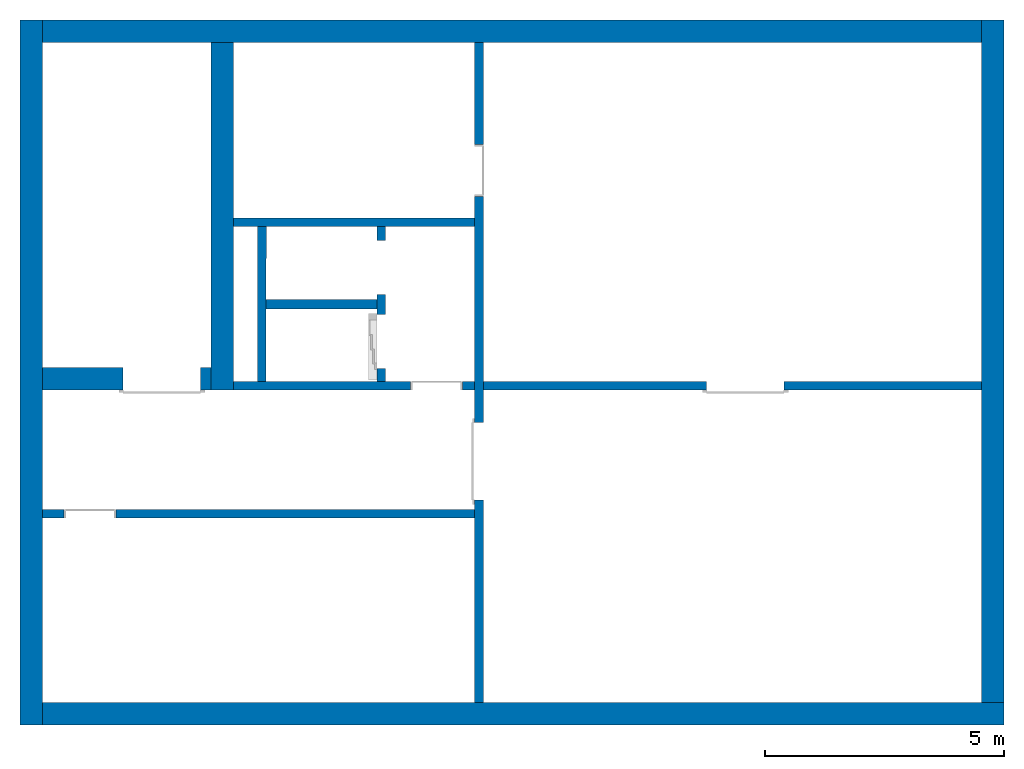
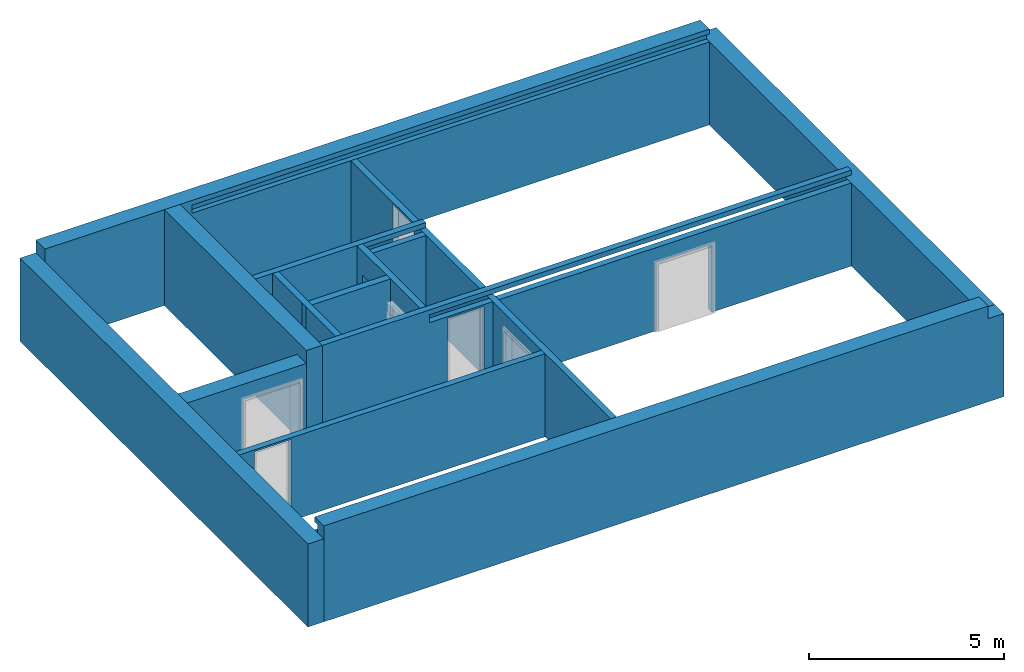
# One storey, part 1 of 3: 13 walls, 8 openings.
"""IFC4 building model written with IfcOpenShell, lengths in metres."""

import ifcopenshell
import ifcopenshell.guid

model = None  # the IFC model being written
_history = None  # IfcOwnerHistory: only IFC2X3 demands one
_inside = {}  # id of a spatial element -> (the spatial element, [elements in it])
_under = {}  # id of a project, library or spatial element -> (it, [spatial elements below it])
_declared = {}  # id of a project -> (the project, [libraries it declares])
_typed = {}  # id of a type object -> (the type object, [elements of that type])
_made_of = {}  # id of a material, layer set ... -> (it, [elements and type objects made of it])


def new_model(schema):
    """Start an empty IFC model of exactly this schema.

    Asked for "IFC4X3", IfcOpenShell would pick the latest addendum, in which some entities
    have other attributes; the version numbers below select the first issue.
    IFC2X3 requires an IfcOwnerHistory on every rooted entity: one is made here for all.
    """
    global model, _history
    if schema == "IFC4X3":
        model = ifcopenshell.file(schema_version=(4, 3, 0, 0))
    else:
        model = ifcopenshell.file(schema=schema)
    _inside.clear()
    _under.clear()
    _declared.clear()
    _typed.clear()
    _made_of.clear()
    _history = None
    if model.schema == "IFC2X3":
        org = make("IfcOrganization", Name="unknown")
        user = make(
            "IfcPersonAndOrganization",
            ThePerson=make("IfcPerson", FamilyName="unknown"),
            TheOrganization=org,
        )
        app = make(
            "IfcApplication",
            ApplicationDeveloper=org,
            Version="unknown",
            ApplicationFullName="unknown",
            ApplicationIdentifier="unknown",
        )
        _history = make(
            "IfcOwnerHistory",
            OwningUser=user,
            OwningApplication=app,
            ChangeAction="ADDED",
            CreationDate=0,
        )
    return model


def make(cls, **values):
    """One entity of the class cls with the attributes given. An attribute that is None is left unset."""
    return model.create_entity(
        cls, **{name: value for name, value in values.items() if value is not None}
    )


def entity(cls, *values):
    """Any entity or typed value of the class cls, its attributes in the order of the schema. None: left unset."""
    e = model.create_entity(cls)
    for i, value in enumerate(values):
        if value is not None:
            e[i] = value
    return e


def rooted(cls, **values):
    """An entity with a GlobalId (a new one), such as an element, a storey or a relation."""
    return make(cls, GlobalId=ifcopenshell.guid.new(), OwnerHistory=_history, **values)


def si_unit(unit_type, name, prefix=None):
    """IfcSIUnit, for example si_unit("LENGTHUNIT", "METRE", prefix="MILLI")."""
    return make("IfcSIUnit", UnitType=unit_type, Prefix=prefix, Name=name)


def converted_unit(unit_type, name, factor, base, dimensions=None, offset=None):
    """IfcConversionBasedUnit, such as the inch: factor (a typed value) times the base unit."""
    return make(
        "IfcConversionBasedUnit"
        if offset is None
        else "IfcConversionBasedUnitWithOffset",
        ConversionOffset=offset,
        Dimensions=None
        if dimensions is None
        else entity("IfcDimensionalExponents", *dimensions),
        UnitType=unit_type,
        Name=name,
        ConversionFactor=make(
            "IfcMeasureWithUnit", ValueComponent=factor, UnitComponent=base
        ),
    )


def derived_unit(unit_type, elements):
    """IfcDerivedUnit: a product of units, each with its exponent."""
    return make(
        "IfcDerivedUnit",
        Elements=[
            make("IfcDerivedUnitElement", Unit=unit, Exponent=power)
            for unit, power in elements
        ],
        UnitType=unit_type,
    )


def assignment(units):
    """IfcUnitAssignment: the units of a project."""
    return None if units is None else make("IfcUnitAssignment", Units=units)


def point(xyz):
    """IfcCartesianPoint."""
    return None if xyz is None else make("IfcCartesianPoint", Coordinates=xyz)


def direction(xyz):
    """IfcDirection."""
    return None if xyz is None else make("IfcDirection", DirectionRatios=xyz)


def frame(location, z_axis=None, x_axis=None):
    """IfcAxis2Placement3D, a coordinate frame: its origin and axes. An axis left out is left unset."""
    return make(
        "IfcAxis2Placement3D",
        Location=point(location),
        Axis=direction(z_axis),
        RefDirection=direction(x_axis),
    )


def origin_with_axes():
    """The frame at (0, 0, 0) with the z axis (0, 0, 1) and the x axis (1, 0, 0) written out."""
    return frame((0.0, 0.0, 0.0), z_axis=(0.0, 0.0, 1.0), x_axis=(1.0, 0.0, 0.0))


def place(relative_to, where):
    """IfcLocalPlacement: puts the frame where relative to a parent placement (None: the world)."""
    return make(
        "IfcLocalPlacement", PlacementRelTo=relative_to, RelativePlacement=where
    )


def context(
    kind, dimensions, precision=None, world=None, true_north=None, identifier=None
):
    """IfcGeometricRepresentationContext, for example the 3D "Model" context."""
    return make(
        "IfcGeometricRepresentationContext",
        ContextIdentifier=identifier,
        ContextType=kind,
        CoordinateSpaceDimension=dimensions,
        Precision=precision,
        WorldCoordinateSystem=world,
        TrueNorth=true_north,
    )


def subcontext(parent, identifier, kind, view, scale=None):
    """IfcGeometricRepresentationSubContext, for example "Body" below "Model"."""
    return make(
        "IfcGeometricRepresentationSubContext",
        ContextIdentifier=identifier,
        ContextType=kind,
        ParentContext=parent,
        TargetScale=scale,
        TargetView=view,
    )


def project(units=None, contexts=None):
    """IfcProject with its units and contexts."""
    return rooted(
        "IfcProject",
        Name="project",
        RepresentationContexts=contexts,
        UnitsInContext=assignment(units),
    )


def spatial(cls, under=None, at=None, **own):
    """A site, building, storey or space (cls), placed at a placement, below another one or the project."""
    s = rooted(cls, ObjectPlacement=at, **own)
    if under is not None:
        _under.setdefault(under.id(), (under, []))[1].append(s)
    return s


def point_list(points):
    """IfcCartesianPointList2D or 3D."""
    cls = (
        "IfcCartesianPointList2D" if len(points[0]) == 2 else "IfcCartesianPointList3D"
    )
    return make(cls, CoordList=points)


def polygons(points, faces, closed=None, point_numbers=None):
    """IfcPolygonalFaceSet: a face is its outer loop, then its inner loops; points numbered from 1."""
    made = []
    for loops in faces:
        if len(loops) == 1:
            made.append(make("IfcIndexedPolygonalFace", CoordIndex=loops[0]))
        else:
            made.append(
                make(
                    "IfcIndexedPolygonalFaceWithVoids",
                    CoordIndex=loops[0],
                    InnerCoordIndices=loops[1:],
                )
            )
    return make(
        "IfcPolygonalFaceSet",
        Coordinates=point_list(points),
        Closed=closed,
        Faces=made,
        PnIndex=point_numbers,
    )


def shape(context_of_items, identifier, shape_type, items):
    """IfcShapeRepresentation: the items that make up one representation, for example the "Body"."""
    return make(
        "IfcShapeRepresentation",
        ContextOfItems=context_of_items,
        RepresentationIdentifier=identifier,
        RepresentationType=shape_type,
        Items=items,
    )


def material(Name=None, Category=None):
    """IfcMaterial."""
    return make("IfcMaterial", Name=Name, Category=Category)


def made_of(thing, what):
    """Note that an element or type object is made of a material, layer set ...; save() writes the relation."""
    if what is not None:
        _made_of.setdefault(what.id(), (what, []))[1].append(thing)
    return thing


def type_object(cls, material=None, **own):
    """A type object (cls), such as IfcWallType, which elements share."""
    return made_of(rooted(cls, **own), material)


def element(
    cls,
    number,
    at=None,
    inside=None,
    cuts=None,
    type_object=None,
    material=None,
    context=None,
    identifier="Body",
    shape_type=None,
    held_by="IfcProductDefinitionShape",
    body=None,
    shapes=None,
    **own,
):
    """One element of the class cls, such as IfcWall. Its Tag is "e" and its number.

    at: its placement. inside: the storey or other place that contains it. cuts: it is an
    opening in that element (IfcRelVoidsElement). A single representation is given by context,
    identifier, shape_type and body (its items); several are given by shapes. held_by: the class
    of the entity that holds the representations. save() writes the other relations.
    """
    e = rooted(cls, Tag="e%d" % number, ObjectPlacement=at, **own)
    if body is not None:
        shapes = [shape(context, identifier, shape_type, body)]
    if shapes is not None:
        e.Representation = make(held_by, Representations=shapes)
    if inside is not None:
        _inside.setdefault(inside.id(), (inside, []))[1].append(e)
    if cuts is not None:
        rooted(
            "IfcRelVoidsElement", RelatingBuildingElement=cuts, RelatedOpeningElement=e
        )
    if type_object is not None:
        _typed.setdefault(type_object.id(), (type_object, []))[1].append(e)
    return made_of(e, material)


def aggregate(whole, parts):
    """IfcRelAggregates: a whole, such as a stair, and the parts it consists of."""
    return rooted("IfcRelAggregates", RelatingObject=whole, RelatedObjects=parts)


def save(model, path):
    """Write the relations noted so far, then the file.

    IfcRelAggregates (storeys below a building ...), IfcRelContainedInSpatialStructure (elements
    in a storey), IfcRelDefinesByType, IfcRelAssociatesMaterial and IfcRelDeclares: one each for
    every whole, place, type object, material and project.
    """
    for whole, parts in _under.values():
        aggregate(whole, parts)
    for where, things in _inside.values():
        rooted(
            "IfcRelContainedInSpatialStructure",
            RelatedElements=things,
            RelatingStructure=where,
        )
    for kind, things in _typed.values():
        rooted("IfcRelDefinesByType", RelatedObjects=things, RelatingType=kind)
    for what, things in _made_of.values():
        rooted("IfcRelAssociatesMaterial", RelatedObjects=things, RelatingMaterial=what)
    for by, libraries in _declared.values():
        rooted("IfcRelDeclares", RelatingContext=by, RelatedDefinitions=libraries)
    model.write(path)


model = new_model("IFC4")

# Units and contexts
model_context = context("Model", 3, precision=1e-05, world=origin_with_axes(), true_north=direction((0.0, 1.0)))
body_context = subcontext(model_context, "Body", "Model", "MODEL_VIEW")
ifc_project = project(units=[si_unit("LENGTHUNIT", "METRE"), si_unit("AREAUNIT", "SQUARE_METRE"), si_unit("VOLUMEUNIT", "CUBIC_METRE"), converted_unit("PLANEANGLEUNIT", "DEGREE", entity("IfcPlaneAngleMeasure", 0.0174532925199433), si_unit("PLANEANGLEUNIT", "RADIAN"), dimensions=[0, 0, 0, 0, 0, 0, 0]), converted_unit("TIMEUNIT", "Year", entity("IfcTimeMeasure", 31557600.0), si_unit("TIMEUNIT", "SECOND"), dimensions=[0, 0, 1, 0, 0, 0, 0]), si_unit("MASSUNIT", "GRAM", prefix="KILO"), si_unit("THERMODYNAMICTEMPERATUREUNIT", "DEGREE_CELSIUS"), si_unit("LUMINOUSINTENSITYUNIT", "LUMEN"), si_unit("ENERGYUNIT", "JOULE", prefix="MEGA"), derived_unit("THERMALCONDUCTANCEUNIT", [(si_unit("POWERUNIT", "WATT"), 1), (si_unit("LENGTHUNIT", "METRE"), -1), (si_unit("THERMODYNAMICTEMPERATUREUNIT", "KELVIN"), -1)]), derived_unit("SPECIFICHEATCAPACITYUNIT", [(si_unit("ENERGYUNIT", "JOULE"), 1), (si_unit("MASSUNIT", "GRAM", prefix="KILO"), -1), (si_unit("THERMODYNAMICTEMPERATUREUNIT", "KELVIN"), -1)]), derived_unit("MASSDENSITYUNIT", [(si_unit("MASSUNIT", "GRAM", prefix="KILO"), 1), (si_unit("VOLUMEUNIT", "CUBIC_METRE"), -1)])], contexts=[model_context])

# Site, building, storey
site_placement = place(None, origin_with_axes())
site = spatial("IfcSite", under=ifc_project, at=site_placement, CompositionType="ELEMENT")
building_placement = place(None, origin_with_axes())
building = spatial("IfcBuilding", under=site, at=building_placement, CompositionType="ELEMENT")
storey_placement = place(None, frame((0.0, 0.0, -3.0), z_axis=(0.0, 0.0, 1.0), x_axis=(1.0, 0.0, 0.0)))
storey = spatial("IfcBuildingStorey", under=building, at=storey_placement, Name="UG", CompositionType="ELEMENT", Elevation=-3.0)

# Walls
ifc_material = material(Name="Stahlbeton")
wall_type_1 = type_object("IfcWallType", Name="Stahlbeton 180", PredefinedType="NOTDEFINED")
wall_1_placement = place(None, frame((29.1377045594425, 7.05499994546755, -3.0), z_axis=(0.0, 0.0, 1.0), x_axis=(0.00164133421967425, 0.999998653010083, 0.0)))
element("IfcWall", 1, at=wall_1_placement, inside=storey, type_object=wall_type_1, material=ifc_material, Name="Wand-001", PredefinedType="NOTDEFINED", context=body_context, shape_type="Tessellation", body=[
    polygons([(0.179704801901014, 0.18, 0.0), (3.41970916615423, 0.180000000000007, 0.0), (3.42000460671172, 0.0, 0.0), (0.180000242458512, 0.0, 0.0), (0.179704801901014, 0.18, 3.0), (3.41970916615423, 0.180000000000007, 3.0), (3.42000460671172, 0.0, 3.0), (0.180000242458512, 0.0, 3.0)], [[[1, 2, 3, 4]], [[5, 6, 2, 1]], [[7, 3, 2, 6]], [[4, 3, 7, 8]], [[8, 5, 1, 4]], [[8, 7, 6, 5]]], closed=True),
])
wall_2_placement = place(None, frame((33.505, 10.6549999454676, -3.0), z_axis=(0.0, 0.0, 1.0), x_axis=(-1.0, 0.0, 0.0)))
element("IfcWall", 2, at=wall_2_placement, inside=storey, type_object=wall_type_1, material=ifc_material, Name="Wand-003", PredefinedType="NOTDEFINED", context=body_context, shape_type="Tessellation", body=[
    polygons([(0.0, 0.18, 3.0), (0.0, 0.180000000000001, 2.85), (0.0, 0.0, 2.85), (0.0, 0.0, 3.0), (1.8669999709129, 0.18, 2.6), (1.8669999709129, 0.18, 2.85), (5.04699999999999, 0.18, 3.0), (5.04699999999999, 0.18, 0.0), (0.0, 0.18, 0.0), (0.0, 0.180000000000003, 2.6), (1.8669999709129, -8.86263311627999e-08, 2.85), (1.8669999709129, -8.86263311627999e-08, 2.6), (0.0, 0.0, 2.6), (0.0, 0.0, 0.0), (5.04699999999999, 0.0, 0.0), (5.04699999999999, 0.0, 3.0)], [[[1, 2, 3, 4]], [[5, 6, 2, 1, 7, 8, 9, 10]], [[6, 11, 3, 2]], [[11, 12, 13, 14, 15, 16, 4, 3]], [[4, 16, 7, 1]], [[5, 12, 11, 6]], [[8, 7, 16, 15]], [[8, 15, 14, 9]], [[14, 13, 10, 9]], [[5, 10, 13, 12]]], closed=True),
])

# Wall, openings
wall_3_placement = place(None, frame((27.988, 7.05499994546755, -3.0), z_axis=(0.0, 0.0, 1.0), x_axis=(1.0, 0.0, 0.0)))
wall_3 = element("IfcWall", 3, at=wall_3_placement, inside=storey, type_object=wall_type_1, material=ifc_material, Name="Wand-001", PredefinedType="NOTDEFINED", context=body_context, shape_type="Tessellation", body=[
    polygons([(10.370657642847, 0.18, 2.11), (10.370657642847, 0.18, 0.0), (5.69699999999999, 0.18, 0.0), (5.69699999999999, 0.180000000000002, 2.6), (8.20499999999999, 0.180000000000002, 2.6), (16.126, 0.180000000000001, 2.6), (16.126, 0.180000000000001, 0.0), (11.990657642847, 0.180000000000001, 0.0), (11.990657642847, 0.180000000000001, 2.11), (10.370657642847, 0.0, 2.11), (10.370657642847, 0.0, 0.0), (5.69699999999999, 0.0, 0.0), (5.69699999999999, 0.0, 2.6), (16.126, 0.0, 2.6), (16.126, 0.0, 0.0), (11.990657642847, 0.0, 0.0), (11.990657642847, 0.0, 2.11)], [[[1, 2, 3, 4, 5, 6, 7, 8, 9]], [[2, 1, 10, 11]], [[2, 11, 12, 3]], [[13, 4, 3, 12]], [[4, 13, 14, 6, 5]], [[6, 14, 15, 7]], [[16, 8, 7, 15]], [[9, 8, 16, 17]], [[1, 9, 17, 10]], [[17, 16, 15, 14, 13, 12, 11, 10]]], closed=True),
    polygons([(4.17199999999999, 0.18, 2.545), (4.17199999999999, 0.18, 0.0), (0.469999999999999, 0.18, 0.0), (0.469999999999999, 0.180000000000001, 3.0), (16.126, 0.180000000000001, 3.0), (16.126, 0.180000000000001, 2.85), (8.20499999999999, 0.180000000000002, 2.85), (5.69699999999999, 0.180000000000002, 2.85), (3.65000002908709, 0.18, 2.85), (3.65000002908709, 0.18, 2.6), (5.51699999999999, 0.18, 2.6), (5.51699999999999, 0.18, 0.0), (5.262, 0.18, 0.0), (5.262, 0.18, 2.545), (4.17199999999999, 1.29097926127031e-07, 2.545), (4.17199999999999, 0.0, 0.0), (0.469999999999999, 0.0, 0.0), (0.469999999999999, 0.0, 2.6), (0.469999999999999, 0.0, 3.0), (16.126, 0.0, 3.0), (16.126, 0.0, 2.85), (3.65000002908709, 1.29097926127031e-07, 2.85), (3.65000002908709, 1.29097926127031e-07, 2.6), (5.51699999999999, 0.0, 2.6), (5.51699999999999, 0.0, 0.0), (5.262, 0.0, 0.0), (5.262, 1.29097926127031e-07, 2.545)], [[[1, 2, 3, 4, 5, 6, 7, 8, 9, 10, 11, 12, 13, 14]], [[2, 1, 15, 16]], [[2, 16, 17, 3]], [[3, 17, 18, 19, 4]], [[5, 4, 19, 20]], [[21, 6, 5, 20]], [[6, 21, 22, 9, 8, 7]], [[10, 9, 22, 23]], [[24, 11, 10, 23]], [[11, 24, 25, 12]], [[26, 13, 12, 25]], [[14, 13, 26, 27]], [[1, 14, 27, 15]], [[27, 26, 25, 24, 23, 22, 21, 20, 19, 18, 17, 16, 15]]], closed=True),
])
opening_1_placement = place(wall_3_placement, frame((4.717, 0.0, 0.0), z_axis=(0.0, 0.0, 1.0), x_axis=(1.0, 0.0, 0.0)))
element("IfcOpeningElement", 4, at=opening_1_placement, cuts=wall_3, context=body_context, identifier="Reference", shape_type="Tessellation", body=[
    polygons([(-0.545000000000002, -0.00100000000000033, 2.545), (-0.545000000000002, -0.00100000000000033, 0.0), (0.545000000000002, -0.00100000000000033, 0.0), (0.545000000000002, -0.00100000000000033, 2.545), (-0.545000000000002, 0.181, 2.545), (-0.545000000000002, 0.181, 0.0), (0.545000000000002, 0.181, 0.0), (0.545000000000002, 0.181, 2.545)], [[[1, 2, 3, 4]], [[5, 6, 2, 1]], [[6, 7, 3, 2]], [[7, 8, 4, 3]], [[8, 5, 1, 4]], [[7, 6, 5, 8]]], closed=True),
])
opening_2_placement = place(wall_3_placement, frame((11.180657642847, 0.0, 0.0), z_axis=(0.0, 0.0, 1.0), x_axis=(1.0, 0.0, 0.0)))
element("IfcOpeningElement", 5, at=opening_2_placement, cuts=wall_3, context=body_context, identifier="Reference", shape_type="Tessellation", body=[
    polygons([(0.810000000000002, 0.181000000000002, 2.11), (0.810000000000002, 0.181000000000002, 0.0), (-0.810000000000002, 0.181000000000002, 0.0), (-0.810000000000002, 0.181000000000003, 2.11), (0.810000000000002, -0.00100000000000478, 2.11), (0.810000000000002, -0.00100000000000478, 0.0), (-0.810000000000002, -0.00100000000000478, 0.0), (-0.810000000000002, -0.00100000000000389, 2.11)], [[[1, 2, 3, 4]], [[5, 6, 2, 1]], [[6, 7, 3, 2]], [[7, 8, 4, 3]], [[8, 5, 1, 4]], [[7, 6, 5, 8]]], closed=True),
])

wall_4_placement = place(None, frame((33.505, 14.3318657372406, -3.0), z_axis=(0.0, 0.0, 1.0), x_axis=(0.0, -1.0, 0.0)))
wall_4 = element("IfcWall", 6, at=wall_4_placement, inside=storey, type_object=wall_type_1, material=ifc_material, Name="Wand-001", PredefinedType="NOTDEFINED", context=body_context, shape_type="Tessellation", body=[
    polygons([(3.22686579177299, 0.18, 0.0), (3.22686579177299, 0.18, 2.545), (2.13686579177299, 0.18, 2.545), (2.13686579177299, 0.18, 0.0), (0.0, 0.18, 0.0), (0.0, 0.18, 2.6), (13.8118657372406, 0.18, 2.6), (13.8118657372406, 0.18, 0.0), (9.57686579177299, 0.18, 0.0), (9.57686579177299, 0.18, 2.11), (7.95686579177299, 0.18, 2.11), (7.95686579177299, 0.18, 0.0), (3.22686579177299, 0.0, 0.0), (3.22686579177299, 0.0, 2.545), (2.13686579177299, 0.0, 2.545), (2.13686579177299, 0.0, 0.0), (0.0, 0.0, 0.0), (0.0, 0.0, 2.6), (13.8118657372406, 0.0, 2.6), (13.8118657372406, 0.0, 0.0), (9.57686579177299, 0.0, 0.0), (9.57686579177299, 0.0, 2.11), (7.95686579177299, 0.0, 2.11), (7.95686579177299, 0.0, 0.0)], [[[1, 2, 3, 4, 5, 6, 7, 8, 9, 10, 11, 12]], [[2, 1, 13, 14]], [[3, 2, 14, 15]], [[4, 3, 15, 16]], [[4, 16, 17, 5]], [[17, 18, 6, 5]], [[6, 18, 19, 7]], [[7, 19, 20, 8]], [[9, 8, 20, 21]], [[9, 21, 22, 10]], [[10, 22, 23, 11]], [[11, 23, 24, 12]], [[13, 1, 12, 24]], [[14, 13, 24, 23, 22, 21, 20, 19, 18, 17, 16, 15]]], closed=True),
])
opening_3_placement = place(None, frame((33.505, 11.6499999454676, -3.0), z_axis=(0.0, 0.0, 1.0), x_axis=(0.0, -1.0, 0.0)))
element("IfcOpeningElement", 7, at=opening_3_placement, cuts=wall_4, context=body_context, identifier="Reference", shape_type="Tessellation", body=[
    polygons([(-0.545, -0.000999999999997669, 2.545), (-0.545, -0.000999999999997669, 0.0), (0.545, -0.000999999999997669, 0.0), (0.545, -0.000999999999997669, 2.545), (-0.545, 0.180999999999997, 2.545), (-0.545, 0.180999999999997, 0.0), (0.545, 0.180999999999997, 0.0), (0.545, 0.180999999999997, 2.545)], [[[1, 2, 3, 4]], [[5, 6, 2, 1]], [[6, 7, 3, 2]], [[7, 8, 4, 3]], [[8, 5, 1, 4]], [[7, 6, 5, 8]]], closed=True),
])
opening_4_placement = place(None, frame((33.505, 5.56499994546756, -3.0), z_axis=(0.0, 0.0, 1.0), x_axis=(0.0, -1.0, 0.0)))
element("IfcOpeningElement", 8, at=opening_4_placement, cuts=wall_4, context=body_context, identifier="Reference", shape_type="Tessellation", body=[
    polygons([(0.81, 0.180999999999997, 2.11), (0.81, 0.180999999999997, 0.0), (-0.81, 0.180999999999997, 0.0), (-0.81, 0.180999999999997, 2.11), (0.81, -0.000999999999997669, 2.11), (0.81, -0.000999999999997669, 0.0), (-0.81, -0.000999999999997669, 0.0), (-0.81, -0.000999999999997669, 2.11)], [[[1, 2, 3, 4]], [[5, 6, 2, 1]], [[6, 7, 3, 2]], [[7, 8, 4, 3]], [[8, 5, 1, 4]], [[7, 6, 5, 8]]], closed=True),
])

wall_5_placement = place(None, frame((31.638, 7.05499994546755, -3.0), z_axis=(0.0, 0.0, 1.0), x_axis=(0.0, 1.0, 0.0)))
wall_5 = element("IfcWall", 9, at=wall_5_placement, inside=storey, type_object=wall_type_1, material=ifc_material, Name="Wand-002", PredefinedType="NOTDEFINED", context=body_context, shape_type="Tessellation", body=[
    polygons([(2.0, 0.0, 0.0), (2.0, 0.0, 2.25), (3.13, 0.0, 2.25), (3.13, 0.0, 0.0), (3.42, 0.0, 0.0), (3.42, 0.0, 3.0), (0.179999999999999, 0.0, 3.0), (0.179999999999999, 0.0, 0.0), (0.450000000000002, 0.0, 0.0), (0.450000000000002, 0.0, 2.25), (1.58, 0.0, 2.25), (1.58, 0.0, 0.0), (2.0, 0.179999999999996, 0.0), (2.0, 0.179999999999996, 2.25), (3.13, 0.179999999999996, 2.25), (3.13, 0.179999999999996, 0.0), (3.42, 0.179999999999996, 0.0), (3.42, 0.179999999999996, 3.0), (0.179999999999999, 0.18, 3.0), (0.179999999999999, 0.18, 0.0), (0.450000000000002, 0.18, 0.0), (0.450000000000002, 0.18, 2.25), (1.58, 0.18, 2.25), (1.58, 0.18, 0.0)], [[[1, 2, 3, 4, 5, 6, 7, 8, 9, 10, 11, 12]], [[2, 1, 13, 14]], [[3, 2, 14, 15]], [[4, 3, 15, 16]], [[4, 16, 17, 5]], [[18, 6, 5, 17]], [[19, 7, 6, 18]], [[8, 7, 19, 20]], [[9, 8, 20, 21]], [[9, 21, 22, 10]], [[10, 22, 23, 11]], [[11, 23, 24, 12]], [[13, 1, 12, 24]], [[14, 13, 24, 23, 22, 21, 20, 19, 18, 17, 16, 15]]], closed=True),
])
opening_5_placement = place(None, frame((31.638, 8.06999994546756, -3.0), z_axis=(0.0, 0.0, 1.0), x_axis=(0.0, 1.0, 0.0)))
element("IfcOpeningElement", 10, at=opening_5_placement, cuts=wall_5, context=body_context, identifier="Reference", shape_type="Tessellation", body=[
    polygons([(-0.565, -0.00100000000000122, 2.25), (-0.565, -0.00100000000000122, 0.0), (0.565, -0.00100000000000122, 0.0), (0.565, -0.00100000000000122, 2.25), (-0.565, 0.181000000000004, 2.25), (-0.565, 0.181000000000004, 0.0), (0.565000000000001, 0.181000000000004, 0.0), (0.565000000000001, 0.181000000000004, 2.25)], [[[1, 2, 3, 4]], [[5, 6, 2, 1]], [[6, 7, 3, 2]], [[7, 8, 4, 3]], [[8, 5, 1, 4]], [[7, 6, 5, 8]]], closed=True),
])
opening_6_placement = place(None, frame((31.638, 9.61999994546755, -3.0), z_axis=(0.0, 0.0, 1.0), x_axis=(0.0, 1.0, 0.0)))
element("IfcOpeningElement", 11, at=opening_6_placement, cuts=wall_5, context=body_context, identifier="Reference", shape_type="Tessellation", body=[
    polygons([(-0.565, -0.00100000000000478, 2.25), (-0.565, -0.00100000000000478, 0.0), (0.565, -0.00100000000000478, 0.0), (0.565, -0.00100000000000478, 2.25), (-0.564999999999998, 0.181000000000001, 2.25), (-0.564999999999998, 0.181000000000001, 0.0), (0.565000000000001, 0.181000000000001, 0.0), (0.565000000000001, 0.181000000000001, 2.25)], [[[1, 2, 3, 4]], [[5, 6, 2, 1]], [[6, 7, 3, 2]], [[7, 8, 4, 3]], [[8, 5, 1, 4]], [[7, 6, 5, 8]]], closed=True),
])

# Wall, opening
wall_6_placement = place(None, frame((33.505, 4.55499994546755, -3.0), z_axis=(0.0, 0.0, 1.0), x_axis=(-1.0, 0.0, 0.0)))
wall_6 = element("IfcWall", 12, at=wall_6_placement, inside=storey, type_object=wall_type_1, material=ifc_material, Name="Wand-003", PredefinedType="NOTDEFINED", context=body_context, shape_type="Tessellation", body=[
    polygons([(8.59699999999999, 0.0, 2.545), (8.59699999999999, 0.0, 0.0), (9.047, 0.0, 0.0), (9.047, 0.0, 2.6), (0.0, 0.0, 2.6), (0.0, 0.0, 0.0), (7.507, 0.0, 0.0), (7.507, 0.0, 2.545), (8.59699999999999, 0.18, 2.545), (8.59699999999999, 0.18, 0.0), (9.047, 0.18, 0.0), (9.047, 0.18, 2.6), (0.0, 0.180000000000001, 2.6), (0.0, 0.18, 0.0), (7.507, 0.18, 0.0), (7.507, 0.18, 2.545)], [[[1, 2, 3, 4, 5, 6, 7, 8]], [[2, 1, 9, 10]], [[2, 10, 11, 3]], [[11, 12, 4, 3]], [[12, 13, 5, 4]], [[14, 6, 5, 13]], [[15, 7, 6, 14]], [[8, 7, 15, 16]], [[1, 8, 16, 9]], [[16, 15, 14, 13, 12, 11, 10, 9]]], closed=True),
])
opening_7_placement = place(None, frame((25.453, 4.55499994546755, -3.0), z_axis=(0.0, 0.0, 1.0), x_axis=(-1.0, 0.0, 0.0)))
element("IfcOpeningElement", 13, at=opening_7_placement, cuts=wall_6, context=body_context, identifier="Reference", shape_type="Tessellation", body=[
    polygons([(-0.544999999999998, -0.00100000000000033, 2.545), (-0.544999999999998, -0.00100000000000033, 0.0), (0.544999999999998, -0.00100000000000033, 0.0), (0.544999999999998, -0.00100000000000033, 2.545), (-0.544999999999998, 0.181, 2.545), (-0.544999999999998, 0.181, 0.0), (0.544999999999998, 0.181, 0.0), (0.544999999999998, 0.181, 2.545)], [[[1, 2, 3, 4]], [[5, 6, 2, 1]], [[6, 7, 3, 2]], [[7, 8, 4, 3]], [[8, 5, 1, 4]], [[7, 6, 5, 8]]], closed=True),
])

# Walls
wall_type_2 = type_object("IfcWallType", Name="Stahlbeton 470", PredefinedType="NOTDEFINED")
wall_7_placement = place(None, frame((27.988, 14.3318657372406, -3.0), z_axis=(0.0, 0.0, 1.0), x_axis=(0.0, -1.0, 0.0)))
element("IfcWall", 14, at=wall_7_placement, inside=storey, type_object=wall_type_2, material=ifc_material, Name="Wand-003", PredefinedType="NOTDEFINED", context=body_context, shape_type="Tessellation", body=[
    polygons([(7.276865791773, 0.469999999999999, 3.0), (7.276865791773, 0.0, 3.0), (7.27686579177299, 0.0, 2.6), (7.27686579177299, 0.469999999999999, 2.6), (0.0, 0.469999999999999, 3.0), (0.0, 0.0, 3.0), (0.0, 0.0, 0.0), (7.27686579177299, 0.0, 0.0), (7.27686579177299, 0.469999999999999, 0.0), (0.0, 0.469999999999999, 0.0)], [[[1, 2, 3, 4]], [[5, 6, 2, 1]], [[6, 7, 8, 3, 2]], [[3, 8, 9, 4]], [[5, 1, 4, 9, 10]], [[6, 5, 10, 7]], [[7, 10, 9, 8]]], closed=True),
])
wall_8_placement = place(None, frame((44.114, 0.52, -3.0), z_axis=(0.0, 0.0, 1.0), x_axis=(0.0, 1.0, 0.0)))
element("IfcWall", 15, at=wall_8_placement, inside=storey, type_object=wall_type_2, material=ifc_material, Name="Wand-003", PredefinedType="NOTDEFINED", context=body_context, shape_type="Tessellation", body=[
    polygons([(14.2818657372405, -0.469999999999999, 2.6), (14.2818657372405, 0.0, 2.6), (0.0, 0.0, 2.6), (0.0, -0.469999999999999, 2.6), (14.2818657372405, -0.469999999999999, 0.0), (14.2818657372405, 0.0, 0.0), (0.0, 0.0, 0.0), (0.0, -0.469999999999999, 0.0)], [[[1, 2, 3, 4]], [[2, 1, 5, 6]], [[2, 6, 7, 3]], [[8, 4, 3, 7]], [[5, 1, 4, 8]], [[6, 5, 8, 7]]], closed=True),
])
wall_9_placement = place(None, frame((44.114, 14.3318657372406, -3.0), z_axis=(0.0, 0.0, 1.0), x_axis=(-1.0, 0.0, 0.0)))
element("IfcWall", 16, at=wall_9_placement, inside=storey, type_object=wall_type_2, material=ifc_material, Name="Wand-004", PredefinedType="NOTDEFINED", context=body_context, shape_type="Tessellation", body=[
    polygons([(0.0, 0.0, 2.85), (0.0, -0.151134016234401, 2.85), (0.0, -0.151134016234401, 2.6), (0.0, -0.470000000000001, 2.6), (0.0, -0.470000000000001, 3.0), (0.0, 0.0, 3.0), (15.306, -0.151134016234401, 2.85), (15.306, 0.0, 2.85), (15.306, -0.151134016234401, 2.6), (0.0, 0.0, 2.6), (0.0, 0.0, 0.0), (0.0, -0.470000000000001, 0.0), (19.656, -0.470000000000002, 3.0), (19.656, -0.470000000000001, 0.0), (19.656, -0.470000000000001, 2.6), (19.656, -0.470000000000002, 2.85), (19.656, 0.0, 3.0), (15.306, 0.0, 2.6), (19.656, 0.0, 2.85), (19.656, 0.0, 2.6), (19.656, 0.0, 0.0)], [[[1, 2, 3, 4, 5, 6]], [[7, 2, 1, 8]], [[9, 3, 2, 7]], [[4, 3, 10, 11, 12]], [[13, 5, 4, 12, 14, 15, 16]], [[6, 5, 13, 17]], [[18, 8, 1, 6, 17, 19, 20, 21, 11, 10]], [[7, 8, 18, 9]], [[18, 10, 3, 9]], [[21, 14, 12, 11]], [[14, 21, 20, 15]], [[19, 16, 15, 20]], [[16, 19, 17, 13]]], closed=True),
])
wall_10_placement = place(None, frame((24.458, 0.52, -3.0), z_axis=(0.0, 0.0, 1.0), x_axis=(1.0, 0.0, 0.0)))
element("IfcWall", 17, at=wall_10_placement, inside=storey, type_object=wall_type_2, material=ifc_material, Name="Wand-002", PredefinedType="NOTDEFINED", context=body_context, shape_type="Tessellation", body=[
    polygons([(19.656, -0.469999999999999, 2.6), (19.656, -0.156999999999999, 2.6), (19.656, -0.156999999999999, 2.85), (19.656, 0.0, 2.85), (19.656, 0.0, 3.0), (19.656, -0.469999999999999, 3.0), (20.126, 0.0, 2.6), (19.656, 0.0, 2.6), (20.126, -0.469999999999999, 2.6), (0.0, -0.156999999999999, 2.85), (0.0, -0.156999999999999, 2.6), (0.0, 0.0, 2.85), (0.0, 0.0, 3.0), (0.0, -0.47, 3.0), (0.0, -0.47, 2.6), (0.0, -0.47, 0.0), (20.126, -0.469999999999999, 0.0), (0.0, 0.0, 0.0), (0.0, 0.0, 2.6), (20.126, 0.0, 0.0)], [[[1, 2, 3, 4, 5, 6]], [[7, 8, 2, 1, 9]], [[10, 3, 2, 11]], [[10, 12, 4, 3]], [[5, 4, 12, 13]], [[5, 13, 14, 6]], [[6, 14, 15, 16, 17, 9, 1]], [[18, 19, 8, 7, 20]], [[11, 2, 8, 19]], [[9, 17, 20, 7]], [[12, 10, 11, 15, 14, 13]], [[15, 11, 19, 18, 16]], [[20, 17, 16, 18]]], closed=True),
])

# Wall, opening
wall_11_placement = place(None, frame((27.988, 7.05499994546755, -3.0), z_axis=(0.0, 0.0, 1.0), x_axis=(-1.0, 0.0, 0.0)))
wall_11 = element("IfcWall", 18, at=wall_11_placement, inside=storey, type_object=wall_type_2, material=ifc_material, Name="Wand-001", PredefinedType="NOTDEFINED", context=body_context, shape_type="Tessellation", body=[
    polygons([(1.84, -0.470000000000001, 2.11), (1.84, -0.47, 0.0), (3.53, -0.470000000000001, 0.0), (3.53, -0.47, 2.6), (0.0, -0.47, 2.6), (0.0, -0.47, 0.0), (0.219999999999999, -0.47, 0.0), (0.219999999999999, -0.470000000000001, 2.11), (1.84, 0.0, 2.11), (1.84, 0.0, 0.0), (3.53, 0.0, 0.0), (3.53, 0.0, 2.6), (0.0, 0.0, 2.6), (0.0, 0.0, 0.0), (0.219999999999999, 0.0, 0.0), (0.219999999999999, 0.0, 2.11)], [[[1, 2, 3, 4, 5, 6, 7, 8]], [[2, 1, 9, 10]], [[2, 10, 11, 3]], [[4, 3, 11, 12]], [[12, 13, 5, 4]], [[5, 13, 14, 6]], [[15, 7, 6, 14]], [[8, 7, 15, 16]], [[1, 8, 16, 9]], [[16, 15, 14, 13, 12, 11, 10, 9]]], closed=True),
])
opening_8_placement = place(None, frame((26.958, 7.05499994546755, -3.0), z_axis=(0.0, 0.0, 1.0), x_axis=(-1.0, 0.0, 0.0)))
element("IfcOpeningElement", 19, at=opening_8_placement, cuts=wall_11, context=body_context, identifier="Reference", shape_type="Tessellation", body=[
    polygons([(-0.809999999999999, -0.471, 2.11), (-0.809999999999999, -0.471, 0.0), (0.809999999999999, -0.471, 0.0), (0.809999999999999, -0.471, 2.11), (-0.809999999999999, 0.00100000000000033, 2.11), (-0.809999999999999, 0.00100000000000033, 0.0), (0.809999999999999, 0.00100000000000033, 0.0), (0.809999999999999, 0.00100000000000033, 2.11)], [[[1, 2, 3, 4]], [[5, 6, 2, 1]], [[6, 7, 3, 2]], [[7, 8, 4, 3]], [[8, 5, 1, 4]], [[7, 6, 5, 8]]], closed=True),
])

# Walls
wall_12_placement = place(None, frame((24.458, 14.3318657372406, -3.0), z_axis=(0.0, 0.0, 1.0), x_axis=(0.0, -1.0, 0.0)))
element("IfcWall", 20, at=wall_12_placement, inside=storey, type_object=wall_type_2, material=ifc_material, Name="Wand-001", PredefinedType="NOTDEFINED", context=body_context, shape_type="Tessellation", body=[
    polygons([(14.2818657372405, -0.469999999999999, 2.6), (14.2818657372405, 0.0, 2.6), (-0.470000000000001, 0.0, 2.6), (-0.469999999999999, -0.469999999999999, 2.6), (14.2818657372405, -0.469999999999999, 0.0), (14.2818657372405, 0.0, 0.0), (-0.470000000000001, 0.0, 0.0), (-0.469999999999999, -0.469999999999999, 0.0)], [[[1, 2, 3, 4]], [[2, 1, 5, 6]], [[2, 6, 7, 3]], [[8, 4, 3, 7]], [[5, 1, 4, 8]], [[6, 5, 8, 7]]], closed=True),
])
wall_type_3 = type_object("IfcWallType", Name="Stahlbeton 200", PredefinedType="NOTDEFINED")
wall_13_placement = place(None, frame((28.958, 8.85499994546755, -3.0), z_axis=(0.0, 0.0, 1.0), x_axis=(1.0, 0.0, 0.0)))
element("IfcWall", 21, at=wall_13_placement, inside=storey, type_object=wall_type_3, material=ifc_material, Name="Wand-001", PredefinedType="NOTDEFINED", context=body_context, shape_type="Tessellation", body=[
    polygons([(0.00282285620201961, 0.0999999999999996, 0.0), (0.00249458891590848, -0.0999999999999996, 0.0), (0.0, -0.0999999999999996, 0.0), (0.0, 0.0999999999999996, 0.0), (0.00282285620201961, 0.0999999999999996, 3.0), (0.00249458891590848, -0.0999999999999996, 3.0), (0.0, -0.0999999999999996, 3.0), (0.0, 0.0999999999999996, 3.0)], [[[1, 2, 3, 4]], [[2, 1, 5, 6]], [[2, 6, 7, 3]], [[8, 4, 3, 7]], [[5, 1, 4, 8]], [[6, 5, 8, 7]]], closed=True),
    polygons([(2.5, 0.0999999999999996, 0.0), (2.5, -0.0999999999999996, 0.0), (0.18249483137442, -0.0999999999999996, 0.0), (0.182823098660531, 0.0999999999999996, 0.0), (2.5, 0.0999999999999996, 3.0), (2.5, -0.0999999999999996, 3.0), (0.18249483137442, -0.0999999999999996, 3.0), (0.182823098660531, 0.0999999999999996, 3.0)], [[[1, 2, 3, 4]], [[2, 1, 5, 6]], [[2, 6, 7, 3]], [[8, 4, 3, 7]], [[5, 1, 4, 8]], [[6, 5, 8, 7]]], closed=True),
])

save(model, "model.ifc")
